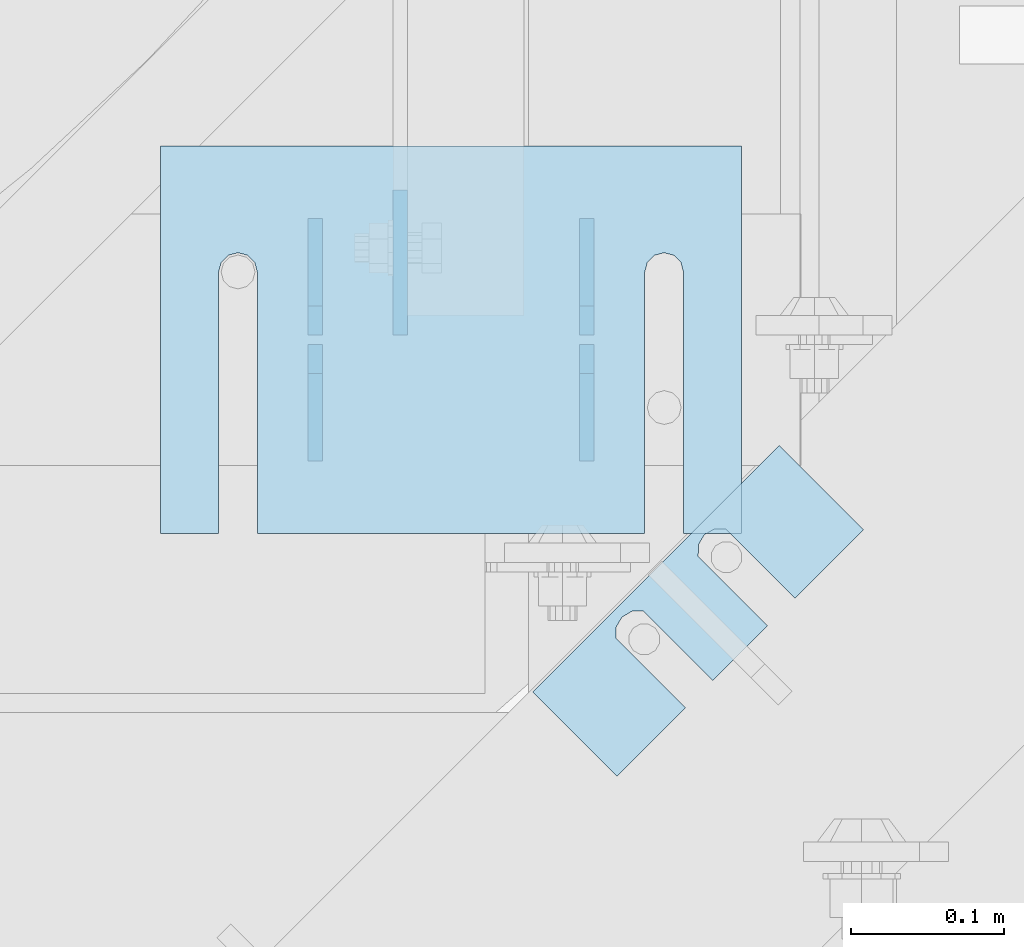
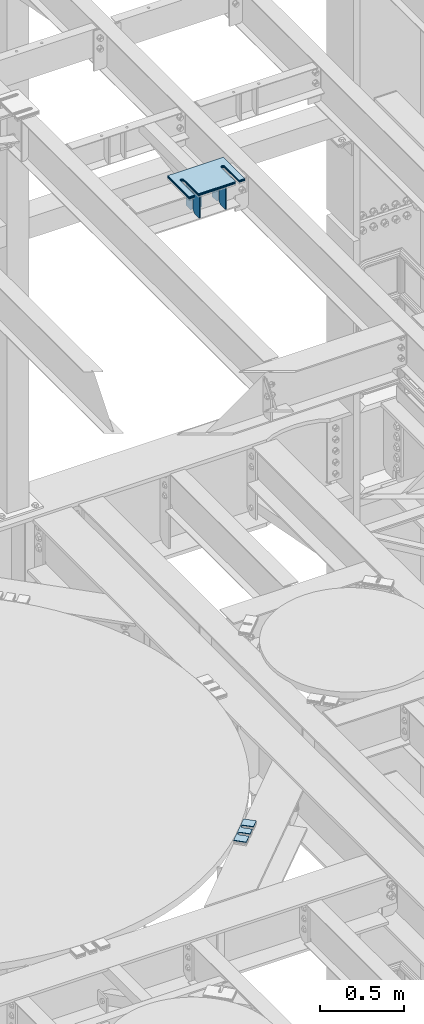
# One storey, part 1783 of 1876: 12 plates, 8 elements without a shape of their own.
"""IFC2X3 building model written with IfcOpenShell, lengths in millimetres."""

from ifc_helpers import new_model, si_unit, frame, origin_with_axes, place, context, subcontext, project, spatial, faceted_brep, material, type_object, element, aggregate, save


model = new_model("IFC2X3")

# Units and contexts
model_context = context("Model", 3, precision=1e-05, world=origin_with_axes())
body_context = subcontext(model_context, "Body", "Model", "MODEL_VIEW")
ifc_project = project(units=[si_unit("LENGTHUNIT", "METRE", prefix="MILLI"), si_unit("AREAUNIT", "SQUARE_METRE"), si_unit("VOLUMEUNIT", "CUBIC_METRE"), si_unit("MASSUNIT", "GRAM", prefix="KILO"), si_unit("TIMEUNIT", "SECOND"), si_unit("PLANEANGLEUNIT", "RADIAN"), si_unit("SOLIDANGLEUNIT", "STERADIAN"), si_unit("THERMODYNAMICTEMPERATUREUNIT", "DEGREE_CELSIUS"), si_unit("LUMINOUSINTENSITYUNIT", "LUMEN")], contexts=[model_context])

# Site, building, storey
site_placement = place(None, origin_with_axes())
site = spatial("IfcSite", under=ifc_project, at=site_placement, CompositionType="ELEMENT")
building_placement = place(site_placement, origin_with_axes())
building = spatial("IfcBuilding", under=site, at=building_placement, Name="Undefined", CompositionType="ELEMENT")
storey_placement = place(building_placement, origin_with_axes())
storey = spatial("IfcBuildingStorey", under=building, at=storey_placement, Name="Undefined", CompositionType="ELEMENT", Elevation=0.0)

# Assembly, plates
assembly_1_placement = place(storey_placement, origin_with_axes())
assembly_1 = element("IfcElementAssembly", 1, at=assembly_1_placement, inside=storey, Name="BEAM", AssemblyPlace="NOTDEFINED", PredefinedType="RIGID_FRAME")
ifc_material = material(Name="STEEL/A36")
plate_type_1 = type_object("IfcPlateType", PredefinedType="NOTDEFINED")
plate_1_placement = place(assembly_1_placement, frame((4508.42445813056, 10185.4012878418, 17792.7), z_axis=(0.0, 0.0, 1.0), x_axis=(0.0, 1.0, 0.0)))
plate_1 = element("IfcPlate", 2, at=plate_1_placement, type_object=plate_type_1, material=ifc_material, Name="PLATE", context=body_context, shape_type="Brep", body=[
    faceted_brep([(0.0, -4.76249999999982, 0.0), (0.0, -4.76249999999982, 180.975006103516), (0.0, 4.76249999999982, 180.975006103516), (0.0, 4.76249999999982, 0.0), (57.1499977111816, -4.76249999999982, 180.975006103516), (57.1499977111816, 4.76249999999982, 180.975006103516), (76.1999969482422, -4.76249999999982, 161.925006866455), (76.1999969482422, 4.76249999999982, 161.925006866455), (76.1999969482422, -4.76249999999982, 19.0499992370605), (76.1999969482422, 4.76249999999982, 19.0499992370605), (57.1499977111816, -4.76249999999982, 0.0), (57.1499977111816, 4.76249999999982, 0.0)], [[[0, 1, 2, 3]], [[1, 4, 5, 2]], [[4, 6, 7, 5]], [[6, 8, 9, 7]], [[8, 10, 11, 9]], [[10, 0, 3, 11]], [[5, 7, 9, 11, 3, 2]], [[10, 8, 6, 4, 1, 0]]]),
])
plate_2_placement = place(assembly_1_placement, frame((4508.42445813056, 10267.9512878418, 17792.7), z_axis=(0.0, 0.0, 1.0), x_axis=(0.0, 1.0, 0.0)))
plate_2 = element("IfcPlate", 3, at=plate_2_placement, type_object=plate_type_1, material=ifc_material, Name="PLATE", context=body_context, shape_type="Brep", body=[
    faceted_brep([(0.0, -4.76249999999982, 19.0499992370605), (0.0, -4.76249999999982, 161.925006866455), (0.0, 4.76249999999982, 161.925006866455), (0.0, 4.76249999999982, 19.0499992370605), (19.0499992370605, -4.76249999999982, 180.975006103516), (19.0499992370605, 4.76249999999982, 180.975006103516), (76.1999969482422, -4.76249999999982, 180.975006103516), (76.1999969482422, 4.76249999999982, 180.975006103516), (76.1999969482422, -4.76250000000073, 0.0), (76.1999969482422, 4.76250000000073, 0.0), (19.0499992370605, -4.76249999999982, 0.0), (19.0499992370605, 4.76249999999982, 0.0)], [[[0, 1, 2, 3]], [[1, 4, 5, 2]], [[4, 6, 7, 5]], [[6, 8, 9, 7]], [[8, 10, 11, 9]], [[10, 0, 3, 11]], [[5, 7, 9, 11, 3, 2]], [[10, 8, 6, 4, 1, 0]]]),
])
plate_3_placement = place(assembly_1_placement, frame((4330.62445813056, 10185.4012878418, 17792.7), z_axis=(0.0, 0.0, 1.0), x_axis=(0.0, 1.0, 0.0)))
plate_3 = element("IfcPlate", 4, at=plate_3_placement, type_object=plate_type_1, material=ifc_material, Name="PLATE", context=body_context, shape_type="Brep", body=[
    faceted_brep([(0.0, -4.76249999999982, 0.0), (0.0, -4.76249999999982, 180.975006103516), (0.0, 4.76249999999982, 180.975006103516), (0.0, 4.76249999999982, 0.0), (57.1499977111816, -4.76249999999982, 180.975006103516), (57.1499977111816, 4.76249999999982, 180.975006103516), (76.1999969482422, -4.76249999999982, 161.925006866455), (76.1999969482422, 4.76249999999982, 161.925006866455), (76.1999969482422, -4.76249999999982, 19.0499992370605), (76.1999969482422, 4.76249999999982, 19.0499992370605), (57.1499977111816, -4.76249999999982, 0.0), (57.1499977111816, 4.76249999999982, 0.0)], [[[0, 1, 2, 3]], [[1, 4, 5, 2]], [[4, 6, 7, 5]], [[6, 8, 9, 7]], [[8, 10, 11, 9]], [[10, 0, 3, 11]], [[5, 7, 9, 11, 3, 2]], [[10, 8, 6, 4, 1, 0]]]),
])
plate_4_placement = place(assembly_1_placement, frame((4330.62445813056, 10267.9512878418, 17792.7), z_axis=(0.0, 0.0, 1.0), x_axis=(0.0, 1.0, 0.0)))
plate_4 = element("IfcPlate", 5, at=plate_4_placement, type_object=plate_type_1, material=ifc_material, Name="PLATE", context=body_context, shape_type="Brep", body=[
    faceted_brep([(0.0, -4.76249999999982, 19.0499992370605), (0.0, -4.76249999999982, 161.925006866455), (0.0, 4.76249999999982, 161.925006866455), (0.0, 4.76249999999982, 19.0499992370605), (19.0499992370605, -4.76249999999982, 180.975006103516), (19.0499992370605, 4.76249999999982, 180.975006103516), (76.1999969482422, -4.76249999999982, 180.975006103516), (76.1999969482422, 4.76249999999982, 180.975006103516), (76.1999969482422, -4.76250000000073, 0.0), (76.1999969482422, 4.76250000000073, 0.0), (19.0499992370605, -4.76249999999982, 0.0), (19.0499992370605, 4.76249999999982, 0.0)], [[[0, 1, 2, 3]], [[1, 4, 5, 2]], [[4, 6, 7, 5]], [[6, 8, 9, 7]], [[8, 10, 11, 9]], [[10, 0, 3, 11]], [[5, 7, 9, 11, 3, 2]], [[10, 8, 6, 4, 1, 0]]]),
])
plate_type_2 = type_object("IfcPlateType", PredefinedType="NOTDEFINED")
plate_5_placement = place(assembly_1_placement, frame((4386.26099208383, 10362.99555764, 17792.6999984957), z_axis=(0.0, -1.0, 0.0), x_axis=(0.0, 0.0, 1.0)))
plate_5 = element("IfcPlate", 6, at=plate_5_placement, type_object=plate_type_2, material=ifc_material, Name="PLATE", context=body_context, shape_type="Brep", body=[
    faceted_brep([(0.0, -4.76249999999982, 0.0), (1.3032513379585e-06, -4.76249999997708, 82.3443193435705), (1.3032513379585e-06, 4.76250000002256, 82.3443193435669), (0.0, 4.76249999999982, 0.0), (12.7000013135184, -4.76249999997344, 95.0443203416271), (12.7000013135184, 4.76250000002619, 95.0443203416253), (81.5056838989258, -4.76249999997344, 95.0443267822302), (81.5056838989258, 4.76250000002619, 95.0443267822266), (81.5056762695312, -4.76249999999982, 5.45696821063757e-12), (81.5056762695312, 4.76249999999982, 0.0)], [[[0, 1, 2, 3]], [[1, 4, 5, 2]], [[4, 6, 7, 5]], [[6, 8, 9, 7]], [[8, 0, 3, 9]], [[5, 7, 9, 3, 2]], [[8, 6, 4, 1, 0]]]),
])
aggregate(assembly_1, [plate_1, plate_2, plate_3, plate_4, plate_5])

# Assembly, plate
assembly_2_placement = place(storey_placement, origin_with_axes())
assembly_2 = element("IfcElementAssembly", 7, at=assembly_2_placement, inside=storey, Name="SHIM PLATE", AssemblyPlace="NOTDEFINED", PredefinedType="RIGID_FRAME")
plate_type_3 = type_object("IfcPlateType", PredefinedType="NOTDEFINED")
plate_6_placement = place(assembly_2_placement, frame((4689.90078812532, 10140.2424941069, 13335.7925), z_axis=(-0.707124703959397, -0.707088857959405, 0.0), x_axis=(-0.707088857959406, 0.707124703959396, 0.0)))
plate_6 = element("IfcPlate", 8, at=plate_6_placement, type_object=plate_type_3, material=ifc_material, Name="SHIM PLATE", context=body_context, shape_type="Brep", body=[
    faceted_brep([(-2.69435986410826e-07, -0.793499999999767, 88.9036802523933), (-2.69435986410826e-07, 0.793499999999767, 88.9036802523933), (64.2890073715625, 0.793499999999767, 88.9052190745724), (64.2890073715625, -0.793499999999767, 88.9052190745724), (69.5243873298787, 0.793499999999767, 83.4915584105911), (69.5243873298787, -0.793499999999767, 83.4915584105911), (64.2896161919252, -0.793499999999767, 63.5071916498637), (64.2896161919252, 0.793499999999767, 63.5071916498637), (-1.92456354852766e-07, 0.793499999999767, 63.5036806291719), (-1.92456354852766e-07, -0.793499999999767, 63.5036806291719), (69.5247366006915, -0.793499999999767, 68.9211033039346), (69.5247366006915, 0.793499999999767, 68.9211033039346), (71.4330651893342, -0.793499999999767, 76.2063766063075), (71.4330651893342, 0.793499999999767, 76.2063766063075), (64.2877911166179, -0.793499999999767, 139.707191628078), (64.2877911166179, 0.793499999999767, 139.707191628078), (-4.23393430537544e-07, 0.793499999999767, 139.703680607393), (-4.23393430537544e-07, -0.793499999999767, 139.703680607393), (69.522911525386, -0.793499999999767, 145.12110328215), (69.522911525386, 0.793499999999767, 145.12110328215), (71.4312401140269, -0.793499999999767, 152.406376584524), (71.4312401140269, 0.793499999999767, 152.406376584524), (69.5225622545713, -0.793499999999767, 159.691558388807), (69.5225622545713, 0.793499999999767, 159.691558388807), (64.287182296257, -0.793499999999767, 165.105219052788), (64.287182296257, 0.793499999999767, 165.105219052788), (-5.00373062095605e-07, -0.793499999999767, 165.103680230615), (-5.00373062095605e-07, 0.793499999999767, 165.103680230615), (-6.92811227054335e-07, -0.793499999999767, 228.601303100698), (-6.92811227054335e-07, 0.793499999999767, 228.601303100698), (78.1460113524699, -0.793499999999767, 228.601303100651), (78.1460113524699, 0.793499999999767, 228.601303100651), (78.1460113525918, -0.793499999999767, -4.91127138957381e-11), (78.1460113525918, 0.793499999999767, -4.91127138957381e-11), (9.09494701772928e-13, -0.793499999999767, 0.0), (9.09494701772928e-13, 0.793499999999767, 0.0)], [[[0, 1, 2, 3]], [[3, 2, 4, 5]], [[6, 7, 8, 9]], [[10, 11, 7, 6]], [[12, 13, 11, 10]], [[5, 4, 13, 12]], [[14, 15, 16, 17]], [[18, 19, 15, 14]], [[20, 21, 19, 18]], [[22, 23, 21, 20]], [[24, 25, 23, 22]], [[26, 27, 25, 24]], [[28, 29, 27, 26]], [[28, 30, 31, 29]], [[30, 32, 33, 31]], [[32, 34, 35, 33]], [[35, 34, 9, 8]], [[2, 1, 16, 15, 19, 21, 23, 25, 27, 29, 31, 33, 35, 8, 7, 11, 13, 4]], [[17, 16, 1, 0]], [[6, 9, 34, 32, 30, 28, 26, 24, 22, 20, 18, 14, 17, 0, 3, 5, 12, 10]]]),
])
aggregate(assembly_2, [plate_6])

assembly_3_placement = place(storey_placement, origin_with_axes())
assembly_3 = element("IfcElementAssembly", 9, at=assembly_3_placement, inside=storey, Name="SHIM PLATE", AssemblyPlace="NOTDEFINED", PredefinedType="RIGID_FRAME")
plate_type_4 = type_object("IfcPlateType", PredefinedType="NOTDEFINED")
plate_7_placement = place(assembly_3_placement, frame((4689.90078812532, 10140.2424941069, 13333.4115), z_axis=(-0.707124703959397, -0.707088857959405, 0.0), x_axis=(-0.707088857959406, 0.707124703959396, 0.0)))
plate_7 = element("IfcPlate", 10, at=plate_7_placement, type_object=plate_type_4, material=ifc_material, Name="SHIM PLATE", context=body_context, shape_type="Brep", body=[
    faceted_brep([(-2.69435986410826e-07, -1.58749999999964, 88.9036802523951), (-2.69435986410826e-07, 1.58749999999964, 88.9036802523951), (64.2890073715644, 1.58749999999964, 88.9052190745733), (64.2890073715644, -1.58749999999964, 88.9052190745733), (69.5243873298787, 1.58749999999964, 83.491558410592), (69.5243873298787, -1.58749999999964, 83.491558410592), (64.2896161919234, -1.58749999999964, 63.5071916498646), (64.2896161919234, 1.58749999999964, 63.5071916498646), (-1.92456354852766e-07, 1.58749999999964, 63.5036806291737), (-1.92456354852766e-07, -1.58749999999964, 63.5036806291737), (69.5247366006934, -1.58749999999964, 68.9211033039355), (69.5247366006934, 1.58749999999964, 68.9211033039355), (71.4330651893342, -1.58749999999964, 76.2063766063084), (71.4330651893342, 1.58749999999964, 76.2063766063084), (64.2877911166179, -1.58749999999964, 139.707191628079), (64.2877911166179, 1.58749999999964, 139.707191628079), (-4.23391611548141e-07, 1.58749999999964, 139.703680607395), (-4.23391611548141e-07, -1.58749999999964, 139.703680607395), (69.522911525386, -1.58749999999964, 145.121103282152), (69.522911525386, 1.58749999999964, 145.121103282152), (71.4312401140269, -1.58749999999964, 152.406376584525), (71.4312401140269, 1.58749999999964, 152.406376584525), (69.5225622545713, -1.58749999999964, 159.691558388808), (69.5225622545713, 1.58749999999964, 159.691558388808), (64.2871822962588, -1.58749999999964, 165.105219052789), (64.2871822962588, 1.58749999999964, 165.105219052789), (-5.00371243106201e-07, -1.58749999999964, 165.103680230615), (-5.00371243106201e-07, 1.58749999999964, 165.103680230615), (-6.92813046043739e-07, -1.58749999999964, 228.601303100699), (-6.92813046043739e-07, 1.58749999999964, 228.601303100699), (78.1460113524699, -1.58749999999964, 228.601303100651), (78.1460113524699, 1.58749999999964, 228.601303100651), (78.1460113525918, -1.58749999999964, -4.72937244921923e-11), (78.1460113525918, 1.58749999999964, -4.72937244921923e-11), (9.09494701772928e-13, -1.58750000000146, 4.54747350886464e-13), (9.09494701772928e-13, 1.58750000000146, 4.54747350886464e-13)], [[[0, 1, 2, 3]], [[3, 2, 4, 5]], [[6, 7, 8, 9]], [[10, 11, 7, 6]], [[12, 13, 11, 10]], [[5, 4, 13, 12]], [[14, 15, 16, 17]], [[18, 19, 15, 14]], [[20, 21, 19, 18]], [[22, 23, 21, 20]], [[24, 25, 23, 22]], [[26, 27, 25, 24]], [[28, 29, 27, 26]], [[28, 30, 31, 29]], [[30, 32, 33, 31]], [[32, 34, 35, 33]], [[35, 34, 9, 8]], [[2, 1, 16, 15, 19, 21, 23, 25, 27, 29, 31, 33, 35, 8, 7, 11, 13, 4]], [[17, 16, 1, 0]], [[6, 9, 34, 32, 30, 28, 26, 24, 22, 20, 18, 14, 17, 0, 3, 5, 12, 10]]]),
])
aggregate(assembly_3, [plate_7])

assembly_4_placement = place(storey_placement, origin_with_axes())
assembly_4 = element("IfcElementAssembly", 11, at=assembly_4_placement, inside=storey, Name="SHIM PLATE", AssemblyPlace="NOTDEFINED", PredefinedType="RIGID_FRAME")
plate_type_5 = type_object("IfcPlateType", PredefinedType="NOTDEFINED")
plate_8_placement = place(assembly_4_placement, frame((4610.09773210635, 10391.7760609403, 18007.0115), z_axis=(0.0, -1.0, 0.0), x_axis=(-1.0, 0.0, 0.0)))
plate_8 = element("IfcPlate", 12, at=plate_8_placement, type_object=plate_type_5, material=ifc_material, Name="SHIM PLATE", context=body_context, shape_type="Brep", body=[
    faceted_brep([(38.1710562683074, -1.58750000000146, 253.999557495119), (38.1732778844053, -1.58750000000146, 82.6182316462764), (38.1732778844053, 1.58750000000146, 82.6182316462764), (38.1710562683074, 1.58750000000146, 253.999557495119), (39.8747477728821, -1.58750000000146, 76.2682283464169), (39.8747477728821, 1.58750000000146, 76.2682283464169), (44.523266268131, -1.58750000000146, 71.6196998169826), (44.523266268131, 1.58750000000146, 71.6196998169826), (50.8732658952267, -1.58750000000146, 69.9182162215529), (50.8732658952267, 1.58750000000146, 69.9182162215529), (57.2232684284982, -1.58750000000146, 71.6196889709886), (57.2232684284982, 1.58750000000146, 71.6196889709886), (61.8717948635667, -1.58750000000146, 76.2682095606051), (61.8717948635667, 1.58750000000146, 76.2682095606051), (63.5732755980398, -1.58750000000146, 82.6182099542939), (63.5732755980398, 1.58750000000146, 82.6182099542939), (63.5710539816291, -1.58750000000146, 253.999557596195), (63.5710539816291, 1.58750000000146, 253.99955749512), (9.09494701772928e-13, -1.58750000000146, 4.54747350886464e-13), (1.89071320164658e-05, -1.58750000000146, 253.999557495117), (1.89071320164658e-05, 1.58750000000146, 253.999557495117), (9.09494701772928e-13, 1.58750000000146, 4.54747350886464e-13), (380.998474121094, -1.58750000000146, -2.41016095969826e-11), (380.998474121094, 1.58750000000146, -2.41016095969826e-11), (380.998504638661, -1.58750000000146, 253.999557495133), (380.998504638661, 1.58750000000146, 253.999557495133), (342.971054337228, 1.58750000000146, 253.999557495132), (342.971054337228, -1.58750000000146, 253.999557596208), (342.973275782132, 1.58750000000146, 82.6182252130961), (342.973275782132, -1.58750000000146, 82.6182252130961), (341.271801399192, 1.58750000000146, 76.2682205744086), (341.271801399192, -1.58750000000146, 76.2682205744086), (336.623277411347, 1.58750000000146, 71.6196940636119), (336.623277411347, -1.58750000000146, 71.6196940636119), (330.273273696123, 1.58750000000146, 69.9182162342554), (330.273273696123, -1.58750000000146, 69.9182162342554), (323.923270846187, 1.58750000000146, 71.6196972929051), (323.923270846187, -1.58750000000146, 71.6196972929051), (319.274749222349, 1.58750000000146, 76.2682261677069), (319.274749222349, -1.58750000000146, 76.2682261677069), (317.573278068704, 1.58750000000146, 82.6182316716777), (317.573278068704, -1.58750000000146, 82.6182316716777), (317.571056623908, -1.58750000000146, 253.99955749513), (317.571056623908, 1.58750000000146, 253.99955749513)], [[[0, 1, 2, 3]], [[4, 5, 2, 1]], [[6, 7, 5, 4]], [[8, 9, 7, 6]], [[10, 11, 9, 8]], [[12, 13, 11, 10]], [[14, 15, 13, 12]], [[16, 17, 15, 14]], [[18, 19, 20, 21]], [[22, 18, 21, 23]], [[24, 22, 23, 25]], [[24, 25, 26, 27]], [[27, 26, 28, 29]], [[29, 28, 30, 31]], [[31, 30, 32, 33]], [[33, 32, 34, 35]], [[35, 34, 36, 37]], [[37, 36, 38, 39]], [[39, 38, 40, 41]], [[42, 41, 40, 43]], [[12, 10, 8, 6, 4, 1, 0, 19, 18, 22, 24, 27, 29, 31, 33, 35, 37, 39, 41, 42, 16, 14]], [[20, 19, 0, 3]], [[43, 40, 38, 36, 34, 32, 30, 28, 26, 25, 23, 21, 20, 3, 2, 5, 7, 9, 11, 13, 15, 17]], [[42, 43, 17, 16]]]),
])
aggregate(assembly_4, [plate_8])

assembly_5_placement = place(storey_placement, origin_with_axes())
assembly_5 = element("IfcElementAssembly", 13, at=assembly_5_placement, inside=storey, Name="SHIM PLATE", AssemblyPlace="NOTDEFINED", PredefinedType="RIGID_FRAME")
plate_9_placement = place(assembly_5_placement, frame((4610.09773210635, 10391.7760609403, 18003.8365), z_axis=(0.0, -1.0, 0.0), x_axis=(-1.0, 0.0, 0.0)))
plate_9 = element("IfcPlate", 14, at=plate_9_placement, type_object=plate_type_5, material=ifc_material, Name="SHIM PLATE", context=body_context, shape_type="Brep", body=[
    faceted_brep([(38.1710562683074, -1.58750000000146, 253.999557495119), (38.1732778844053, -1.58750000000146, 82.6182316462764), (38.1732778844053, 1.58750000000146, 82.6182316462764), (38.1710562683074, 1.58750000000146, 253.999557495119), (39.8747477728821, -1.58750000000146, 76.2682283464169), (39.8747477728821, 1.58750000000146, 76.2682283464169), (44.523266268131, -1.58750000000146, 71.6196998169826), (44.523266268131, 1.58750000000146, 71.6196998169826), (50.8732658952267, -1.58750000000146, 69.9182162215529), (50.8732658952267, 1.58750000000146, 69.9182162215529), (57.2232684284982, -1.58750000000146, 71.6196889709886), (57.2232684284982, 1.58750000000146, 71.6196889709886), (61.8717948635667, -1.58750000000146, 76.2682095606051), (61.8717948635667, 1.58750000000146, 76.2682095606051), (63.5732755980398, -1.58750000000146, 82.6182099542939), (63.5732755980398, 1.58750000000146, 82.6182099542939), (63.5710539816291, -1.58750000000146, 253.999557596195), (63.5710539816291, 1.58750000000146, 253.99955749512), (9.09494701772928e-13, -1.58750000000146, 4.54747350886464e-13), (1.89071320164658e-05, -1.58750000000146, 253.999557495117), (1.89071320164658e-05, 1.58750000000146, 253.999557495117), (9.09494701772928e-13, 1.58750000000146, 4.54747350886464e-13), (380.998474121094, -1.58750000000146, -2.41016095969826e-11), (380.998474121094, 1.58750000000146, -2.41016095969826e-11), (380.998504638661, -1.58750000000146, 253.999557495133), (380.998504638661, 1.58750000000146, 253.999557495133), (342.971054337228, 1.58750000000146, 253.999557495132), (342.971054337228, -1.58750000000146, 253.999557596208), (342.973275782132, 1.58750000000146, 82.6182252130961), (342.973275782132, -1.58750000000146, 82.6182252130961), (341.271801399192, 1.58750000000146, 76.2682205744086), (341.271801399192, -1.58750000000146, 76.2682205744086), (336.623277411347, 1.58750000000146, 71.6196940636119), (336.623277411347, -1.58750000000146, 71.6196940636119), (330.273273696123, 1.58750000000146, 69.9182162342554), (330.273273696123, -1.58750000000146, 69.9182162342554), (323.923270846187, 1.58750000000146, 71.6196972929051), (323.923270846187, -1.58750000000146, 71.6196972929051), (319.274749222349, 1.58750000000146, 76.2682261677069), (319.274749222349, -1.58750000000146, 76.2682261677069), (317.573278068704, 1.58750000000146, 82.6182316716777), (317.573278068704, -1.58750000000146, 82.6182316716777), (317.571056623908, -1.58750000000146, 253.99955749513), (317.571056623908, 1.58750000000146, 253.99955749513)], [[[0, 1, 2, 3]], [[4, 5, 2, 1]], [[6, 7, 5, 4]], [[8, 9, 7, 6]], [[10, 11, 9, 8]], [[12, 13, 11, 10]], [[14, 15, 13, 12]], [[16, 17, 15, 14]], [[18, 19, 20, 21]], [[22, 18, 21, 23]], [[24, 22, 23, 25]], [[24, 25, 26, 27]], [[27, 26, 28, 29]], [[29, 28, 30, 31]], [[31, 30, 32, 33]], [[33, 32, 34, 35]], [[35, 34, 36, 37]], [[37, 36, 38, 39]], [[39, 38, 40, 41]], [[42, 41, 40, 43]], [[12, 10, 8, 6, 4, 1, 0, 19, 18, 22, 24, 27, 29, 31, 33, 35, 37, 39, 41, 42, 16, 14]], [[20, 19, 0, 3]], [[43, 40, 38, 36, 34, 32, 30, 28, 26, 25, 23, 21, 20, 3, 2, 5, 7, 9, 11, 13, 15, 17]], [[42, 43, 17, 16]]]),
])
aggregate(assembly_5, [plate_9])

assembly_6_placement = place(storey_placement, origin_with_axes())
assembly_6 = element("IfcElementAssembly", 15, at=assembly_6_placement, inside=storey, Name="SHIM PLATE", AssemblyPlace="NOTDEFINED", PredefinedType="RIGID_FRAME")
plate_type_6 = type_object("IfcPlateType", PredefinedType="NOTDEFINED")
plate_10_placement = place(assembly_6_placement, frame((4610.09773210635, 10391.7760609403, 18009.3925), z_axis=(0.0, -1.0, 0.0), x_axis=(-1.0, 0.0, 0.0)))
plate_10 = element("IfcPlate", 16, at=plate_10_placement, type_object=plate_type_6, material=ifc_material, Name="SHIM PLATE", context=body_context, shape_type="Brep", body=[
    faceted_brep([(38.1710562683074, -0.793499999999767, 253.999557495119), (38.1732778844053, -0.793499999999767, 82.6182316462764), (38.1732778844053, 0.793499999999767, 82.6182316462764), (38.1710562683074, 0.793499999999767, 253.999557495119), (39.8747477728821, -0.793499999999767, 76.2682283464169), (39.8747477728821, 0.793499999999767, 76.2682283464169), (44.523266268131, -0.793499999999767, 71.6196998169826), (44.523266268131, 0.793499999999767, 71.6196998169826), (50.8732658952267, -0.793499999999767, 69.9182162215529), (50.8732658952267, 0.793499999999767, 69.9182162215529), (57.2232684284982, -0.793499999999767, 71.6196889709886), (57.2232684284982, 0.793499999999767, 71.6196889709886), (61.8717948635667, -0.793499999999767, 76.2682095606051), (61.8717948635667, 0.793499999999767, 76.2682095606051), (63.5732755980398, -0.793499999999767, 82.6182099542939), (63.5732755980398, 0.793499999999767, 82.6182099542939), (63.5710539816291, -0.793499999999767, 253.999557596195), (63.5710539816291, 0.793499999999767, 253.99955749512), (9.09494701772928e-13, -0.793499999999767, 0.0), (1.89070156011439e-05, -0.793499999999767, 253.999557495117), (1.89070156011439e-05, 0.793499999999767, 253.999557495117), (9.09494701772928e-13, 0.793499999999767, 0.0), (380.998474121094, -0.793499999999767, -2.41016095969826e-11), (380.998474121094, 0.793499999999767, -2.41016095969826e-11), (380.998504638661, -0.793499999999767, 253.999557495133), (380.998504638661, 0.793499999999767, 253.999557495133), (342.971054337228, 0.793499999999767, 253.999557495132), (342.971054337228, -0.793499999999767, 253.999557596208), (342.973275782132, 0.793499999999767, 82.6182252130961), (342.973275782132, -0.793499999999767, 82.6182252130961), (341.271801399192, 0.793499999999767, 76.2682205744086), (341.271801399192, -0.793499999999767, 76.2682205744086), (336.623277411347, 0.793499999999767, 71.6196940636119), (336.623277411347, -0.793499999999767, 71.6196940636119), (330.273273696123, 0.793499999999767, 69.9182162342554), (330.273273696123, -0.793499999999767, 69.9182162342554), (323.923270846187, 0.793499999999767, 71.6196972929051), (323.923270846187, -0.793499999999767, 71.6196972929051), (319.274749222349, 0.793499999999767, 76.2682261677069), (319.274749222349, -0.793499999999767, 76.2682261677069), (317.573278068704, 0.793499999999767, 82.6182316716777), (317.573278068704, -0.793499999999767, 82.6182316716777), (317.571056623908, -0.793499999999767, 253.99955749513), (317.571056623908, 0.793499999999767, 253.99955749513)], [[[0, 1, 2, 3]], [[4, 5, 2, 1]], [[6, 7, 5, 4]], [[8, 9, 7, 6]], [[10, 11, 9, 8]], [[12, 13, 11, 10]], [[14, 15, 13, 12]], [[16, 17, 15, 14]], [[18, 19, 20, 21]], [[22, 18, 21, 23]], [[24, 22, 23, 25]], [[24, 25, 26, 27]], [[27, 26, 28, 29]], [[29, 28, 30, 31]], [[31, 30, 32, 33]], [[33, 32, 34, 35]], [[35, 34, 36, 37]], [[37, 36, 38, 39]], [[39, 38, 40, 41]], [[42, 41, 40, 43]], [[12, 10, 8, 6, 4, 1, 0, 19, 18, 22, 24, 27, 29, 31, 33, 35, 37, 39, 41, 42, 16, 14]], [[20, 19, 0, 3]], [[43, 40, 38, 36, 34, 32, 30, 28, 26, 25, 23, 21, 20, 3, 2, 5, 7, 9, 11, 13, 15, 17]], [[42, 43, 17, 16]]]),
])
aggregate(assembly_6, [plate_10])

assembly_7_placement = place(storey_placement, origin_with_axes())
assembly_7 = element("IfcElementAssembly", 17, at=assembly_7_placement, inside=storey, Name="SHIM PLATE", AssemblyPlace="NOTDEFINED", PredefinedType="RIGID_FRAME")
plate_type_7 = type_object("IfcPlateType", PredefinedType="NOTDEFINED")
plate_11_placement = place(assembly_7_placement, frame((4610.09773210635, 10391.7760609403, 17999.868), z_axis=(0.0, -1.0, 0.0), x_axis=(-1.0, 0.0, 0.0)))
plate_11 = element("IfcPlate", 18, at=plate_11_placement, type_object=plate_type_7, material=ifc_material, Name="SHIM PLATE", context=body_context, shape_type="Brep", body=[
    faceted_brep([(38.1710562683056, -2.38100000000122, 253.999557495119), (38.1732778844034, -2.38100000000122, 82.6182316462764), (38.1732778844034, 2.38100000000122, 82.6182316462764), (38.1710562683056, 2.38100000000122, 253.999557495119), (39.8747477728803, -2.38100000000122, 76.2682283464169), (39.8747477728803, 2.38100000000122, 76.2682283464169), (44.5232662681292, -2.38100000000122, 71.6196998169826), (44.5232662681292, 2.38100000000122, 71.6196998169826), (50.8732658952249, -2.38100000000122, 69.9182162215529), (50.8732658952249, 2.38100000000122, 69.9182162215529), (57.2232684284963, -2.38100000000122, 71.6196889709886), (57.2232684284963, 2.38100000000122, 71.6196889709886), (61.8717948635649, -2.38100000000122, 76.2682095606051), (61.8717948635649, 2.38100000000122, 76.2682095606051), (63.573275598038, -2.38100000000122, 82.6182099542939), (63.573275598038, 2.38100000000122, 82.6182099542939), (63.5710539816273, -2.38100000000122, 253.999557596195), (63.5710539816273, 2.38100000000122, 253.99955749512), (0.0, -2.38100000000122, 4.54747350886464e-13), (1.89072484317876e-05, -2.38100000000122, 253.999557495117), (1.89072484317876e-05, 2.38100000000122, 253.999557495117), (0.0, 2.38100000000122, 4.54747350886464e-13), (380.998474121094, -2.38100000000122, -2.41016095969826e-11), (380.998474121094, 2.38100000000122, -2.41016095969826e-11), (380.998504638661, -2.38100000000122, 253.999557495133), (380.998504638661, 2.38100000000122, 253.999557495133), (342.971054337227, 2.38100000000122, 253.999557495132), (342.971054337227, -2.38100000000122, 253.999557596208), (342.97327578213, 2.38100000000122, 82.6182252130961), (342.97327578213, -2.38100000000122, 82.6182252130961), (341.27180139919, 2.38100000000122, 76.2682205744086), (341.27180139919, -2.38100000000122, 76.2682205744086), (336.623277411345, 2.38100000000122, 71.6196940636119), (336.623277411345, -2.38100000000122, 71.6196940636119), (330.273273696122, 2.38100000000122, 69.9182162342554), (330.273273696122, -2.38100000000122, 69.9182162342554), (323.923270846185, 2.38100000000122, 71.6196972929051), (323.923270846185, -2.38100000000122, 71.6196972929051), (319.274749222347, 2.38100000000122, 76.2682261677069), (319.274749222347, -2.38100000000122, 76.2682261677069), (317.573278068702, 2.38100000000122, 82.6182316716777), (317.573278068702, -2.38100000000122, 82.6182316716777), (317.571056623906, -2.38100000000122, 253.99955749513), (317.571056623906, 2.38100000000122, 253.99955749513)], [[[0, 1, 2, 3]], [[4, 5, 2, 1]], [[6, 7, 5, 4]], [[8, 9, 7, 6]], [[10, 11, 9, 8]], [[12, 13, 11, 10]], [[14, 15, 13, 12]], [[16, 17, 15, 14]], [[18, 19, 20, 21]], [[22, 18, 21, 23]], [[24, 22, 23, 25]], [[24, 25, 26, 27]], [[27, 26, 28, 29]], [[29, 28, 30, 31]], [[31, 30, 32, 33]], [[33, 32, 34, 35]], [[35, 34, 36, 37]], [[37, 36, 38, 39]], [[39, 38, 40, 41]], [[42, 41, 40, 43]], [[12, 10, 8, 6, 4, 1, 0, 19, 18, 22, 24, 27, 29, 31, 33, 35, 37, 39, 41, 42, 16, 14]], [[20, 19, 0, 3]], [[43, 40, 38, 36, 34, 32, 30, 28, 26, 25, 23, 21, 20, 3, 2, 5, 7, 9, 11, 13, 15, 17]], [[42, 43, 17, 16]]]),
])
aggregate(assembly_7, [plate_11])

assembly_8_placement = place(storey_placement, origin_with_axes())
assembly_8 = element("IfcElementAssembly", 19, at=assembly_8_placement, inside=storey, Name="SHIM PLATE", AssemblyPlace="NOTDEFINED", PredefinedType="RIGID_FRAME")
plate_12_placement = place(assembly_8_placement, frame((4610.09773210635, 10391.7760609403, 17995.106), z_axis=(0.0, -1.0, 0.0), x_axis=(-1.0, 0.0, 0.0)))
plate_12 = element("IfcPlate", 20, at=plate_12_placement, type_object=plate_type_7, material=ifc_material, Name="SHIM PLATE", context=body_context, shape_type="Brep", body=[
    faceted_brep([(38.1710562683056, -2.38100000000122, 253.999557495119), (38.1732778844034, -2.38100000000122, 82.6182316462764), (38.1732778844034, 2.38100000000122, 82.6182316462764), (38.1710562683056, 2.38100000000122, 253.999557495119), (39.8747477728803, -2.38100000000122, 76.2682283464169), (39.8747477728803, 2.38100000000122, 76.2682283464169), (44.5232662681292, -2.38100000000122, 71.6196998169826), (44.5232662681292, 2.38100000000122, 71.6196998169826), (50.8732658952249, -2.38100000000122, 69.9182162215529), (50.8732658952249, 2.38100000000122, 69.9182162215529), (57.2232684284963, -2.38100000000122, 71.6196889709886), (57.2232684284963, 2.38100000000122, 71.6196889709886), (61.8717948635649, -2.38100000000122, 76.2682095606051), (61.8717948635649, 2.38100000000122, 76.2682095606051), (63.573275598038, -2.38100000000122, 82.6182099542939), (63.573275598038, 2.38100000000122, 82.6182099542939), (63.5710539816273, -2.38100000000122, 253.999557596195), (63.5710539816273, 2.38100000000122, 253.99955749512), (0.0, -2.38100000000122, 4.54747350886464e-13), (1.89072484317876e-05, -2.38100000000122, 253.999557495117), (1.89072484317876e-05, 2.38100000000122, 253.999557495117), (0.0, 2.38100000000122, 4.54747350886464e-13), (380.998474121094, -2.38100000000122, -2.41016095969826e-11), (380.998474121094, 2.38100000000122, -2.41016095969826e-11), (380.998504638661, -2.38100000000122, 253.999557495133), (380.998504638661, 2.38100000000122, 253.999557495133), (342.971054337227, 2.38100000000122, 253.999557495132), (342.971054337227, -2.38100000000122, 253.999557596208), (342.97327578213, 2.38100000000122, 82.6182252130961), (342.97327578213, -2.38100000000122, 82.6182252130961), (341.27180139919, 2.38100000000122, 76.2682205744086), (341.27180139919, -2.38100000000122, 76.2682205744086), (336.623277411345, 2.38100000000122, 71.6196940636119), (336.623277411345, -2.38100000000122, 71.6196940636119), (330.273273696122, 2.38100000000122, 69.9182162342554), (330.273273696122, -2.38100000000122, 69.9182162342554), (323.923270846185, 2.38100000000122, 71.6196972929051), (323.923270846185, -2.38100000000122, 71.6196972929051), (319.274749222347, 2.38100000000122, 76.2682261677069), (319.274749222347, -2.38100000000122, 76.2682261677069), (317.573278068702, 2.38100000000122, 82.6182316716777), (317.573278068702, -2.38100000000122, 82.6182316716777), (317.571056623906, -2.38100000000122, 253.99955749513), (317.571056623906, 2.38100000000122, 253.99955749513)], [[[0, 1, 2, 3]], [[4, 5, 2, 1]], [[6, 7, 5, 4]], [[8, 9, 7, 6]], [[10, 11, 9, 8]], [[12, 13, 11, 10]], [[14, 15, 13, 12]], [[16, 17, 15, 14]], [[18, 19, 20, 21]], [[22, 18, 21, 23]], [[24, 22, 23, 25]], [[24, 25, 26, 27]], [[27, 26, 28, 29]], [[29, 28, 30, 31]], [[31, 30, 32, 33]], [[33, 32, 34, 35]], [[35, 34, 36, 37]], [[37, 36, 38, 39]], [[39, 38, 40, 41]], [[42, 41, 40, 43]], [[12, 10, 8, 6, 4, 1, 0, 19, 18, 22, 24, 27, 29, 31, 33, 35, 37, 39, 41, 42, 16, 14]], [[20, 19, 0, 3]], [[43, 40, 38, 36, 34, 32, 30, 28, 26, 25, 23, 21, 20, 3, 2, 5, 7, 9, 11, 13, 15, 17]], [[42, 43, 17, 16]]]),
])
aggregate(assembly_8, [plate_12])

save(model, "model.ifc")
